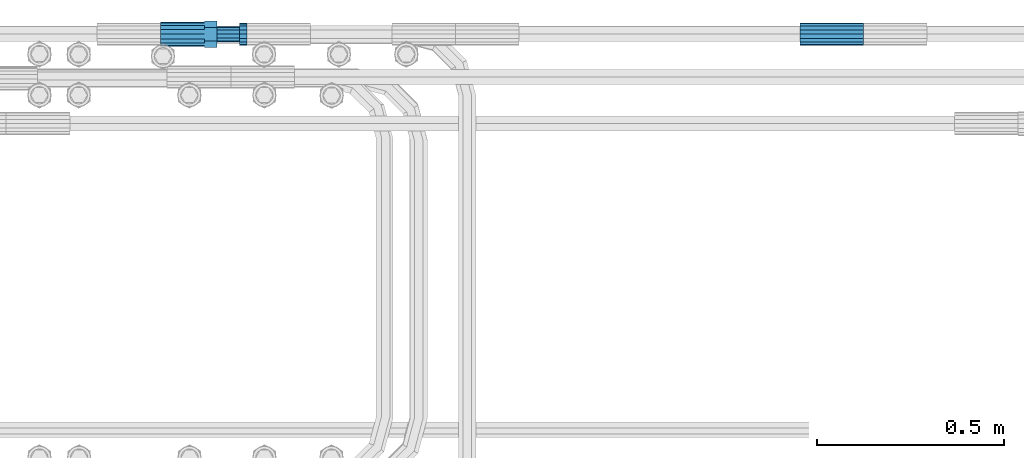
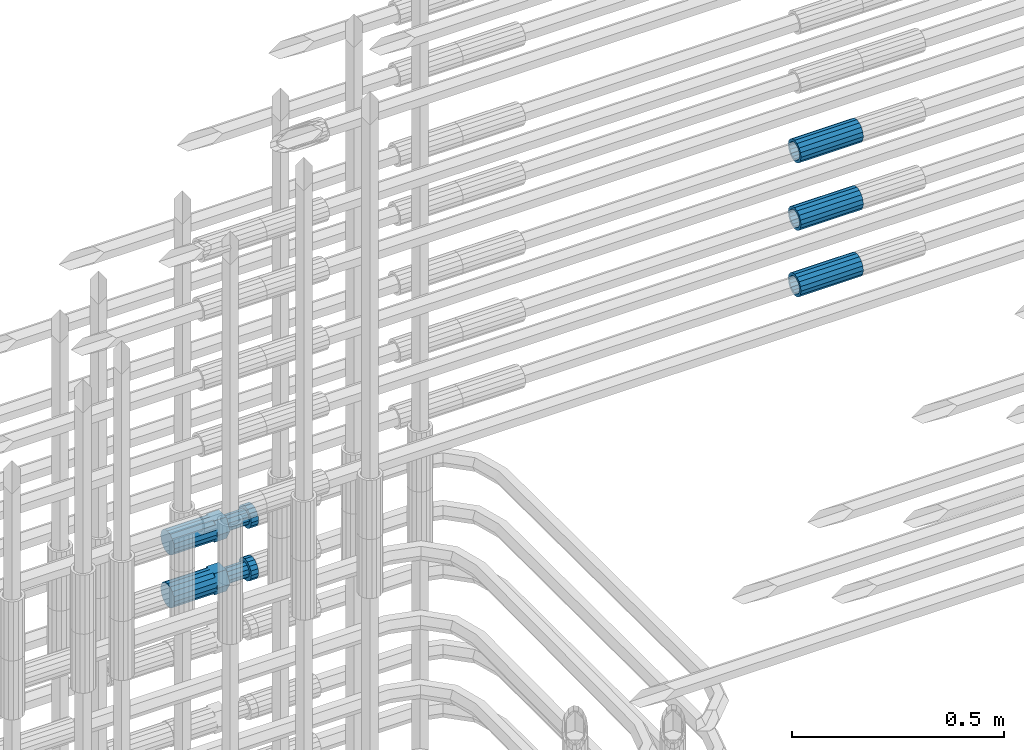
# One storey, part 82 of 119: 5 beams.
"""IFC2X3 building model written with IfcOpenShell, lengths in millimetres."""

from ifc_helpers import new_model, si_unit, frame, origin_with_axes, place, context, subcontext, project, spatial, faceted_brep, material, type_object, element, save


model = new_model("IFC2X3")

# Units and contexts
model_context = context("Model", 3, precision=1e-05, world=origin_with_axes())
body_context = subcontext(model_context, "Body", "Model", "MODEL_VIEW")
ifc_project = project(units=[si_unit("LENGTHUNIT", "METRE", prefix="MILLI"), si_unit("AREAUNIT", "SQUARE_METRE"), si_unit("VOLUMEUNIT", "CUBIC_METRE"), si_unit("MASSUNIT", "GRAM", prefix="KILO"), si_unit("TIMEUNIT", "SECOND"), si_unit("PLANEANGLEUNIT", "RADIAN"), si_unit("SOLIDANGLEUNIT", "STERADIAN"), si_unit("THERMODYNAMICTEMPERATUREUNIT", "DEGREE_CELSIUS"), si_unit("LUMINOUSINTENSITYUNIT", "LUMEN")], contexts=[model_context])

# Site, building, storey
site_placement = place(None, origin_with_axes())
site = spatial("IfcSite", under=ifc_project, at=site_placement, CompositionType="ELEMENT")
building_placement = place(site_placement, origin_with_axes())
building = spatial("IfcBuilding", under=site, at=building_placement, Name="Undefined", CompositionType="ELEMENT")
storey_placement = place(building_placement, origin_with_axes())
storey = spatial("IfcBuildingStorey", under=building, at=storey_placement, Name="Undefined", CompositionType="ELEMENT", Elevation=0.0)

# Beams
ifc_material = material(Name="STEEL/S275")
beam_type_1 = type_object("IfcBeamType", PredefinedType="NOTDEFINED")
beam_1_placement = place(storey_placement, frame((2037555.89023304, 6206399.98994599, 21049.6894003832), z_axis=(0.0, 0.0, 1.0), x_axis=(1.0, 0.0, 0.0)))
element("IfcBeam", 1, at=beam_1_placement, inside=storey, type_object=beam_type_1, material=ifc_material, Name="AG40N", context=body_context, shape_type="Brep", body=[
    faceted_brep([(1.62981450557709e-09, -23.4999999990687, 0.0), (7.45058059692383e-09, -21.7111690142192, 8.99306066057534), (170.000002125278, -21.711168999318, 8.99306066022245), (170.000002127141, -23.4999999844003, -3.66071617463604e-10), (4.65661287307739e-09, -16.6170093587134, 16.6170093578889), (170.000002122484, -16.6170093440451, 16.6170093575288), (1.86264514923096e-09, -8.99306066217832, 21.7111690140277), (170.000002118759, -8.99306064750999, 21.7111690136603), (2.3283064365387e-10, 9.31322574615479e-10, 23.5), (170.000002114102, 1.28056854009628e-08, 23.4999999996485), (-6.51925802230835e-09, 8.99306065868586, 21.7111690140241), (170.00000211224, 8.99306067335419, 21.7111690136639), (-7.45058059692383e-09, 16.6170093561523, 16.6170093578853), (170.000002109446, 16.6170093708206, 16.6170093575324), (-9.31322574615479e-09, 21.711169013055, 8.99306066057534), (170.000002108514, 21.7111690277234, 8.99306066022245), (-1.16415321826935e-09, 23.5000000009313, 0.0), (170.000002108514, 23.5000000144355, -3.66071617463604e-10), (-8.38190317153931e-09, 21.7111690151505, -8.99306066059444), (170.000002110377, 21.7111690300517, -8.9930606609546), (-5.58793544769287e-09, 16.6170093598776, -16.6170093579008), (170.000002113171, 16.6170093745459, -16.6170093582609), (-9.31322574615479e-10, 8.99306066334248, -21.7111690140396), (170.000002115965, 8.99306067801081, -21.7111690143961), (2.3283064365387e-10, 9.31322574615479e-10, -23.5), (170.00000211969, 1.7927959561348e-08, -23.5000000003843), (5.58793544769287e-09, -8.99306065752171, -21.7111690140396), (170.000002123415, -8.99306064285338, -21.7111690143961), (8.38190317153931e-09, -16.6170093549881, -16.6170093579008), (170.000002125278, -16.6170093403198, -16.6170093582646), (9.31322574615479e-09, -21.7111690121237, -8.99306066059444), (170.000002127141, -21.7111689972226, -8.9930606609546), (1.11758708953857e-08, -30.4999999990687, -9.54969436861575e-12), (1.30385160446167e-08, -28.1783257392235, -11.6718446871514), (170.000002129003, -28.1783257243223, -11.6718446875116), (170.000002129935, -30.4999999841675, -3.66071617463604e-10), (1.02445483207703e-08, -21.5667568228673, -21.5667568262129), (170.000002128072, -21.566756808199, -21.5667568265694), (7.45058059692383e-09, -11.6718446831219, -28.1783257416196), (170.000002125278, -11.6718446684536, -28.1783257419834), (3.72529029846191e-09, 3.95812094211578e-09, -30.5000000000277), (170.00000211969, 1.83936208486557e-08, -30.5000000003879), (-9.31322574615479e-10, 11.6718446905725, -28.1783257416232), (170.000002115965, 11.6718447052408, -28.1783257419797), (-6.51925802230835e-09, 21.5667568286881, -21.5667568262093), (170.000002110377, 21.5667568433564, -21.5667568265694), (-9.31322574615479e-09, 28.178325742716, -11.6718446871478), (170.000002108514, 28.1783257573843, -11.6718446875079), (-1.21071934700012e-08, 30.5, -5.91171556152403e-12), (170.000002106652, 30.5000000144355, -3.62433638656512e-10), (-1.21071934700012e-08, 28.1783257401548, 11.6718446871359), (170.00000210572, 28.1783257548232, 11.6718446867794), (-1.02445483207703e-08, 21.5667568240315, 21.5667568261974), (170.000002107583, 21.566756838467, 21.5667568258409), (-7.45058059692383e-09, 11.671844684286, 28.1783257416041), (170.000002110377, 11.6718446989544, 28.178325741244), (-2.79396772384644e-09, -2.56113708019257e-09, 30.5000000000159), (170.000002114102, 1.18743628263474e-08, 30.4999999996558), (1.86264514923096e-09, -11.6718446896411, 28.1783257416114), (170.000002118759, -11.67184467474, 28.178325741244), (7.45058059692383e-09, -21.5667568275239, 21.5667568261974), (170.000002123415, -21.5667568126228, 21.5667568258373), (1.02445483207703e-08, -28.1783257415518, 11.6718446871359), (170.000002127141, -28.1783257271163, 11.6718446867794)], [[[0, 1, 2, 3]], [[1, 4, 5, 2]], [[4, 6, 7, 5]], [[6, 8, 9, 7]], [[8, 10, 11, 9]], [[10, 12, 13, 11]], [[12, 14, 15, 13]], [[14, 16, 17, 15]], [[16, 18, 19, 17]], [[18, 20, 21, 19]], [[20, 22, 23, 21]], [[22, 24, 25, 23]], [[24, 26, 27, 25]], [[26, 28, 29, 27]], [[28, 30, 31, 29]], [[30, 0, 3, 31]], [[32, 33, 34, 35]], [[33, 36, 37, 34]], [[36, 38, 39, 37]], [[38, 40, 41, 39]], [[40, 42, 43, 41]], [[42, 44, 45, 43]], [[44, 46, 47, 45]], [[46, 48, 49, 47]], [[48, 50, 51, 49]], [[50, 52, 53, 51]], [[52, 54, 55, 53]], [[54, 56, 57, 55]], [[56, 58, 59, 57]], [[58, 60, 61, 59]], [[60, 62, 63, 61]], [[62, 32, 35, 63]], [[37, 39, 41, 43, 45, 47, 49, 51, 53, 55, 57, 59, 61, 63, 35, 34], [5, 7, 9, 11, 13, 15, 17, 19, 21, 23, 25, 27, 29, 31, 3, 2]], [[62, 60, 58, 56, 54, 52, 50, 48, 46, 44, 42, 40, 38, 36, 33, 32], [30, 28, 26, 24, 22, 20, 18, 16, 14, 12, 10, 8, 6, 4, 1, 0]]]),
])
beam_2_placement = place(storey_placement, frame((2037555.89023304, 6206399.98994599, 21240.9894003832), z_axis=(0.0, 0.0, 1.0), x_axis=(1.0, 0.0, 0.0)))
element("IfcBeam", 2, at=beam_2_placement, inside=storey, type_object=beam_type_1, material=ifc_material, Name="AG40N", context=body_context, shape_type="Brep", body=[
    faceted_brep([(1.62981450557709e-09, -23.4999999990687, 0.0), (7.45058059692383e-09, -21.7111690142192, 8.99306066057534), (170.000002125278, -21.711168999318, 8.99306066022245), (170.000002127141, -23.4999999844003, -3.66071617463604e-10), (4.65661287307739e-09, -16.6170093587134, 16.6170093578889), (170.000002122484, -16.6170093440451, 16.6170093575288), (1.86264514923096e-09, -8.99306066217832, 21.7111690140277), (170.000002118759, -8.99306064750999, 21.7111690136603), (2.3283064365387e-10, 9.31322574615479e-10, 23.5), (170.000002114102, 1.28056854009628e-08, 23.4999999996485), (-6.51925802230835e-09, 8.99306065868586, 21.7111690140241), (170.00000211224, 8.99306067335419, 21.7111690136639), (-7.45058059692383e-09, 16.6170093561523, 16.6170093578853), (170.000002109446, 16.6170093708206, 16.6170093575324), (-9.31322574615479e-09, 21.711169013055, 8.99306066057534), (170.000002108514, 21.7111690277234, 8.99306066022245), (-1.16415321826935e-09, 23.5000000009313, 0.0), (170.000002108514, 23.5000000144355, -3.66071617463604e-10), (-8.38190317153931e-09, 21.7111690151505, -8.99306066059444), (170.000002110377, 21.7111690300517, -8.9930606609546), (-5.58793544769287e-09, 16.6170093598776, -16.6170093579008), (170.000002113171, 16.6170093745459, -16.6170093582609), (-9.31322574615479e-10, 8.99306066334248, -21.7111690140396), (170.000002115965, 8.99306067801081, -21.7111690143961), (2.3283064365387e-10, 9.31322574615479e-10, -23.5), (170.00000211969, 1.7927959561348e-08, -23.5000000003843), (5.58793544769287e-09, -8.99306065752171, -21.7111690140396), (170.000002123415, -8.99306064285338, -21.7111690143961), (8.38190317153931e-09, -16.6170093549881, -16.6170093579008), (170.000002125278, -16.6170093403198, -16.6170093582646), (9.31322574615479e-09, -21.7111690121237, -8.99306066059444), (170.000002127141, -21.7111689972226, -8.9930606609546), (1.11758708953857e-08, -30.4999999990687, -9.54969436861575e-12), (1.30385160446167e-08, -28.1783257392235, -11.6718446871514), (170.000002129003, -28.1783257243223, -11.6718446875116), (170.000002129935, -30.4999999841675, -3.66071617463604e-10), (1.02445483207703e-08, -21.5667568228673, -21.5667568262129), (170.000002128072, -21.566756808199, -21.5667568265694), (7.45058059692383e-09, -11.6718446831219, -28.1783257416196), (170.000002125278, -11.6718446684536, -28.1783257419834), (3.72529029846191e-09, 3.95812094211578e-09, -30.5000000000277), (170.00000211969, 1.83936208486557e-08, -30.5000000003879), (-9.31322574615479e-10, 11.6718446905725, -28.1783257416232), (170.000002115965, 11.6718447052408, -28.1783257419797), (-6.51925802230835e-09, 21.5667568286881, -21.5667568262093), (170.000002110377, 21.5667568433564, -21.5667568265694), (-9.31322574615479e-09, 28.178325742716, -11.6718446871478), (170.000002108514, 28.1783257573843, -11.6718446875079), (-1.21071934700012e-08, 30.5, -5.91171556152403e-12), (170.000002106652, 30.5000000144355, -3.62433638656512e-10), (-1.21071934700012e-08, 28.1783257401548, 11.6718446871359), (170.00000210572, 28.1783257548232, 11.6718446867794), (-1.02445483207703e-08, 21.5667568240315, 21.5667568261974), (170.000002107583, 21.566756838467, 21.5667568258409), (-7.45058059692383e-09, 11.671844684286, 28.1783257416041), (170.000002110377, 11.6718446989544, 28.178325741244), (-2.79396772384644e-09, -2.56113708019257e-09, 30.5000000000159), (170.000002114102, 1.18743628263474e-08, 30.4999999996558), (1.86264514923096e-09, -11.6718446896411, 28.1783257416114), (170.000002118759, -11.67184467474, 28.178325741244), (7.45058059692383e-09, -21.5667568275239, 21.5667568261974), (170.000002123415, -21.5667568126228, 21.5667568258373), (1.02445483207703e-08, -28.1783257415518, 11.6718446871359), (170.000002127141, -28.1783257271163, 11.6718446867794)], [[[0, 1, 2, 3]], [[1, 4, 5, 2]], [[4, 6, 7, 5]], [[6, 8, 9, 7]], [[8, 10, 11, 9]], [[10, 12, 13, 11]], [[12, 14, 15, 13]], [[14, 16, 17, 15]], [[16, 18, 19, 17]], [[18, 20, 21, 19]], [[20, 22, 23, 21]], [[22, 24, 25, 23]], [[24, 26, 27, 25]], [[26, 28, 29, 27]], [[28, 30, 31, 29]], [[30, 0, 3, 31]], [[32, 33, 34, 35]], [[33, 36, 37, 34]], [[36, 38, 39, 37]], [[38, 40, 41, 39]], [[40, 42, 43, 41]], [[42, 44, 45, 43]], [[44, 46, 47, 45]], [[46, 48, 49, 47]], [[48, 50, 51, 49]], [[50, 52, 53, 51]], [[52, 54, 55, 53]], [[54, 56, 57, 55]], [[56, 58, 59, 57]], [[58, 60, 61, 59]], [[60, 62, 63, 61]], [[62, 32, 35, 63]], [[37, 39, 41, 43, 45, 47, 49, 51, 53, 55, 57, 59, 61, 63, 35, 34], [5, 7, 9, 11, 13, 15, 17, 19, 21, 23, 25, 27, 29, 31, 3, 2]], [[62, 60, 58, 56, 54, 52, 50, 48, 46, 44, 42, 40, 38, 36, 33, 32], [30, 28, 26, 24, 22, 20, 18, 16, 14, 12, 10, 8, 6, 4, 1, 0]]]),
])
beam_3_placement = place(storey_placement, frame((2037555.89023304, 6206399.98994599, 21434.9894003832), z_axis=(0.0, 0.0, 1.0), x_axis=(1.0, 0.0, 0.0)))
element("IfcBeam", 3, at=beam_3_placement, inside=storey, type_object=beam_type_1, material=ifc_material, Name="AG40N", context=body_context, shape_type="Brep", body=[
    faceted_brep([(1.62981450557709e-09, -23.4999999990687, 0.0), (7.45058059692383e-09, -21.7111690142192, 8.99306066057534), (170.000002125278, -21.711168999318, 8.99306066022245), (170.000002127141, -23.4999999844003, -3.66071617463604e-10), (4.65661287307739e-09, -16.6170093587134, 16.6170093578889), (170.000002122484, -16.6170093440451, 16.6170093575288), (1.86264514923096e-09, -8.99306066217832, 21.7111690140277), (170.000002118759, -8.99306064750999, 21.7111690136603), (2.3283064365387e-10, 9.31322574615479e-10, 23.5), (170.000002114102, 1.28056854009628e-08, 23.4999999996485), (-6.51925802230835e-09, 8.99306065868586, 21.7111690140241), (170.00000211224, 8.99306067335419, 21.7111690136639), (-7.45058059692383e-09, 16.6170093561523, 16.6170093578853), (170.000002109446, 16.6170093708206, 16.6170093575324), (-9.31322574615479e-09, 21.711169013055, 8.99306066057534), (170.000002108514, 21.7111690277234, 8.99306066022245), (-1.16415321826935e-09, 23.5000000009313, 0.0), (170.000002108514, 23.5000000144355, -3.66071617463604e-10), (-8.38190317153931e-09, 21.7111690151505, -8.99306066059444), (170.000002110377, 21.7111690300517, -8.9930606609546), (-5.58793544769287e-09, 16.6170093598776, -16.6170093579008), (170.000002113171, 16.6170093745459, -16.6170093582609), (-9.31322574615479e-10, 8.99306066334248, -21.7111690140396), (170.000002115965, 8.99306067801081, -21.7111690143961), (2.3283064365387e-10, 9.31322574615479e-10, -23.5), (170.00000211969, 1.7927959561348e-08, -23.5000000003843), (5.58793544769287e-09, -8.99306065752171, -21.7111690140396), (170.000002123415, -8.99306064285338, -21.7111690143961), (8.38190317153931e-09, -16.6170093549881, -16.6170093579008), (170.000002125278, -16.6170093403198, -16.6170093582646), (9.31322574615479e-09, -21.7111690121237, -8.99306066059444), (170.000002127141, -21.7111689972226, -8.9930606609546), (1.11758708953857e-08, -30.4999999990687, -9.54969436861575e-12), (1.30385160446167e-08, -28.1783257392235, -11.6718446871514), (170.000002129003, -28.1783257243223, -11.6718446875116), (170.000002129935, -30.4999999841675, -3.66071617463604e-10), (1.02445483207703e-08, -21.5667568228673, -21.5667568262129), (170.000002128072, -21.566756808199, -21.5667568265694), (7.45058059692383e-09, -11.6718446831219, -28.1783257416196), (170.000002125278, -11.6718446684536, -28.1783257419834), (3.72529029846191e-09, 3.95812094211578e-09, -30.5000000000277), (170.00000211969, 1.83936208486557e-08, -30.5000000003879), (-9.31322574615479e-10, 11.6718446905725, -28.1783257416232), (170.000002115965, 11.6718447052408, -28.1783257419797), (-6.51925802230835e-09, 21.5667568286881, -21.5667568262093), (170.000002110377, 21.5667568433564, -21.5667568265694), (-9.31322574615479e-09, 28.178325742716, -11.6718446871478), (170.000002108514, 28.1783257573843, -11.6718446875079), (-1.21071934700012e-08, 30.5, -5.91171556152403e-12), (170.000002106652, 30.5000000144355, -3.62433638656512e-10), (-1.21071934700012e-08, 28.1783257401548, 11.6718446871359), (170.00000210572, 28.1783257548232, 11.6718446867794), (-1.02445483207703e-08, 21.5667568240315, 21.5667568261974), (170.000002107583, 21.566756838467, 21.5667568258409), (-7.45058059692383e-09, 11.671844684286, 28.1783257416041), (170.000002110377, 11.6718446989544, 28.178325741244), (-2.79396772384644e-09, -2.56113708019257e-09, 30.5000000000159), (170.000002114102, 1.18743628263474e-08, 30.4999999996558), (1.86264514923096e-09, -11.6718446896411, 28.1783257416114), (170.000002118759, -11.67184467474, 28.178325741244), (7.45058059692383e-09, -21.5667568275239, 21.5667568261974), (170.000002123415, -21.5667568126228, 21.5667568258373), (1.02445483207703e-08, -28.1783257415518, 11.6718446871359), (170.000002127141, -28.1783257271163, 11.6718446867794)], [[[0, 1, 2, 3]], [[1, 4, 5, 2]], [[4, 6, 7, 5]], [[6, 8, 9, 7]], [[8, 10, 11, 9]], [[10, 12, 13, 11]], [[12, 14, 15, 13]], [[14, 16, 17, 15]], [[16, 18, 19, 17]], [[18, 20, 21, 19]], [[20, 22, 23, 21]], [[22, 24, 25, 23]], [[24, 26, 27, 25]], [[26, 28, 29, 27]], [[28, 30, 31, 29]], [[30, 0, 3, 31]], [[32, 33, 34, 35]], [[33, 36, 37, 34]], [[36, 38, 39, 37]], [[38, 40, 41, 39]], [[40, 42, 43, 41]], [[42, 44, 45, 43]], [[44, 46, 47, 45]], [[46, 48, 49, 47]], [[48, 50, 51, 49]], [[50, 52, 53, 51]], [[52, 54, 55, 53]], [[54, 56, 57, 55]], [[56, 58, 59, 57]], [[58, 60, 61, 59]], [[60, 62, 63, 61]], [[62, 32, 35, 63]], [[37, 39, 41, 43, 45, 47, 49, 51, 53, 55, 57, 59, 61, 63, 35, 34], [5, 7, 9, 11, 13, 15, 17, 19, 21, 23, 25, 27, 29, 31, 3, 2]], [[62, 60, 58, 56, 54, 52, 50, 48, 46, 44, 42, 40, 38, 36, 33, 32], [30, 28, 26, 24, 22, 20, 18, 16, 14, 12, 10, 8, 6, 4, 1, 0]]]),
])
beam_type_2 = type_object("IfcBeamType", Name="ROD65", PredefinedType="NOTDEFINED")
beam_4_placement = place(storey_placement, frame((2035848.65023304, 6206399.98994599, 20754.6894158506), z_axis=(0.0, 0.0, 1.0), x_axis=(1.0, 0.0, 0.0)))
element("IfcBeam", 4, at=beam_4_placement, inside=storey, type_object=beam_type_2, material=ifc_material, Name="AGB40", ObjectType="ROD65", context=body_context, shape_type="Brep", body=[
    faceted_brep([(116.999999999069, 17.8249999252148, 30.8738056446964), (116.999999998137, 22.0056957420893, 23.632628078838), (116.999999999069, 12.4372115600854, 30.0260848066173), (116.999999999069, 8.17543111252598, 30.8738056446964), (117.000000000931, -17.8250000746921, 30.8738056446964), (150.200000001118, -17.8250000723638, 30.8738056446964), (150.199999999255, 17.8249999275431, 30.8738056446964), (117.000000000931, -8.17543109622784, 30.8738056446964), (117.000000001863, -22.0056959956419, 23.6326278985034), (117.000000000931, -12.4372115437873, 30.0260848066173), (117.000000001863, -35.6500000746455, -2.18278728425503e-10), (150.200000002049, -35.6500000723172, -2.18278728425503e-10), (117.000000001863, -30.8443149488885, 8.32369080289209), (117.000000001863, -30.8443149488885, -8.32369080355784), (117.000000002794, -32.4999999918509, 0.0), (117.000000000931, -17.8250000746921, -30.873805645133), (150.200000001118, -17.8250000723638, -30.873805645133), (117.000000001863, -22.0056959961075, -23.6326278982269), (117.000000000931, -8.17543109389953, -30.873805645133), (117.000000000931, -12.4372115437873, -30.0260848066173), (116.999999999069, 17.8249999252148, -30.873805645133), (150.199999999255, 17.8249999275431, -30.873805645133), (116.999999999069, 8.17543111019768, -30.873805645133), (116.999999999069, 12.4372115600854, -30.0260848066173), (116.999999998137, 22.005695742555, -23.6326280785652), (116.999999998137, 35.6499999251682, -2.18278728425503e-10), (150.199999998324, 35.6499999277294, -2.18278728425503e-10), (116.999999998137, 30.8443150522653, -8.32369036550881), (116.999999997206, 32.5000000081491, 0.0), (116.999999998137, 30.8443150522653, 8.32369036483942), (1.86264514923096e-09, -22.9809703885112, 22.9809703885621), (1.86264514923096e-09, -30.0260848065373, 12.4372115518672), (117.000000001863, -30.0260847983882, 12.4372115518672), (117.000000001863, -22.9809703803621, 22.9809703885621), (-1.86264514923096e-09, 22.9809703885112, -22.9809703885621), (-1.86264514923096e-09, 30.0260848065373, -12.4372115518672), (116.999999998137, 30.0260848146863, -12.4372115518672), (116.999999998137, 22.9809703966603, -22.9809703885621), (1.86264514923096e-09, -30.0260848065373, -12.4372115518672), (1.86264514923096e-09, -22.9809703885112, -22.9809703885621), (117.000000001863, -22.9809703803621, -22.9809703885621), (117.000000001863, -30.0260847983882, -12.4372115518672), (9.31322574615479e-10, -12.4372115519363, 30.0260848066173), (0.0, 0.0, 32.5), (-9.31322574615479e-10, 12.4372115519363, 30.0260848066173), (-1.86264514923096e-09, 22.9809703885112, 22.9809703885621), (-1.86264514923096e-09, 30.0260848065373, 12.4372115518672), (-2.79396772384644e-09, 32.5, 0.0), (-9.31322574615479e-10, 12.4372115519363, -30.0260848066173), (0.0, 0.0, -32.5), (9.31322574615479e-10, -12.4372115519363, -30.0260848066173), (2.79396772384644e-09, -32.5, 0.0), (116.999999998137, 22.9809703966603, 22.9809703885621), (116.999999998137, 30.0260848146863, 12.4372115518672), (117.0, 8.14907252788544e-09, -32.5), (117.0, 8.14907252788544e-09, 32.5), (150.200000000186, -10.5000000959262, 18.1865334791873), (150.199999999255, -9.59262251853943e-08, 20.9999999997126), (150.199999998324, 10.4999999040738, 18.1865334791873), (150.199999997392, 18.1865333835594, 10.4999999997126), (150.199999997392, 20.9999999040738, -2.87400325760245e-10), (150.199999997392, 18.1865333835594, -10.5000000002874), (150.199999998324, 10.4999999040738, -18.1865334797621), (150.199999999255, -9.59262251853943e-08, -21.0000000002874), (150.200000000186, -10.5000000959262, -18.1865334797621), (150.200000000186, -18.1865335754119, -10.5000000002874), (150.200000001118, -21.0000000959262, -2.87400325760245e-10), (150.200000000186, -18.1865335754119, 10.4999999997126), (210.979999999516, 10.4999999082647, 18.1865334791873), (210.979999999516, -9.17352735996246e-08, 20.9999999997126), (210.979999997653, 18.1865333877504, 10.4999999997126), (210.979999997653, 20.9999999082647, -2.87400325760245e-10), (210.979999997653, 18.1865333877504, -10.5000000002874), (210.979999999516, 10.4999999082647, -18.1865334797621), (210.979999999516, -9.17352735996246e-08, -21.0000000002874), (210.979999999516, -10.5000000917353, -18.1865334797621), (210.980000000447, -18.1865335712209, -10.5000000002874), (210.980000001378, -21.0000000917353, -2.87400325760245e-10), (210.980000000447, -18.1865335712209, 10.4999999997126), (210.979999999516, -10.5000000917353, 18.1865334791873), (211.001368402503, -27.7269939335529, -11.4911163272045), (211.003082515672, -21.2238095656503, -21.2238154190527), (231.002518340945, -21.2131946226582, -21.2132004554769), (231.000804228708, -27.7163789905608, -11.4805013636287), (211.001368415542, -11.4911086384673, -27.7269970399575), (231.000804241747, -11.4804936954752, -27.7163820763781), (210.996487061493, -0.0106066407170147, -30.0106107396168), (230.995922887698, 8.30227509140968e-06, -29.999995776041), (210.98918159306, 11.4698940692469, -27.7269970332745), (230.988617419265, 11.4805090120062, -27.7163820696951), (210.980564201251, 21.2025913291145, -21.2238154067054), (230.980000027455, 21.2132062721066, -21.2132004431296), (210.971946807578, 27.7057702087332, -11.4911163110701), (230.971382633783, 27.7163851517253, -11.4805013474943), (210.964641331695, 29.9893806746695, -0.0106149565435771), (230.9640771579, 29.9999956176616, 7.03221303410828e-09), (210.959759964608, 27.7057637346443, 11.4698863966551), (230.959195790812, 27.7163786776364, 11.4805013602345), (210.958045851439, 21.2025793667417, 21.2025854885032), (230.957481677644, 21.2131943097338, 21.2132004520827), (210.959759951569, 11.4698784395587, 27.705767109408), (230.959195776843, 11.4804933823179, 27.7163820729838), (210.964641305618, -0.0106235581915826, 29.9893808090674), (230.964077131823, -8.61519947648048e-06, 29.9999957726432), (210.971946774051, -11.4911242681555, 27.7057671027251), (230.971382599324, -11.4805093251634, 27.7163820663009), (210.98056416586, -21.2238215280231, 21.2025854761559), (230.979999991134, -21.2132065852638, 21.2132004397354), (210.989181559533, -27.7270004076418, 11.4698863805206), (230.988617384806, -27.7163854646496, 11.4805013441), (210.996487035416, -30.0106108735781, -0.0106149740058754), (230.995922861621, -29.999995930586, -1.04300852399319e-08)], [[[0, 1, 2, 3]], [[4, 5, 6, 0, 3, 7]], [[8, 4, 7, 9]], [[10, 11, 5, 4, 8, 12]], [[13, 10, 12, 14]], [[15, 16, 11, 10, 13, 17]], [[18, 15, 17, 19]], [[20, 21, 16, 15, 18, 22]], [[20, 22, 23, 24]], [[25, 26, 21, 20, 24, 27]], [[25, 27, 28, 29]], [[30, 31, 32, 33]], [[34, 35, 36, 37]], [[38, 39, 40, 41]], [[31, 30, 42, 43, 44, 45, 46, 47, 35, 34, 48, 49, 50, 39, 38, 51]], [[46, 45, 52, 53]], [[28, 47, 46, 53, 29]], [[27, 36, 35, 47, 28]], [[24, 37, 36, 27]], [[23, 48, 34, 37, 24]], [[22, 54, 49, 48, 23]], [[18, 54, 22]], [[19, 50, 49, 54, 18]], [[17, 40, 39, 50, 19]], [[13, 41, 40, 17]], [[14, 51, 38, 41, 13]], [[12, 32, 31, 51, 14]], [[8, 33, 32, 12]], [[9, 42, 30, 33, 8]], [[7, 55, 43, 42, 9]], [[3, 55, 7]], [[2, 44, 43, 55, 3]], [[1, 52, 45, 44, 2]], [[29, 53, 52, 1]], [[0, 6, 26, 25, 29, 1]], [[5, 11, 16, 21, 26, 6], [56, 57, 58, 59, 60, 61, 62, 63, 64, 65, 66, 67]], [[68, 58, 57, 69]], [[70, 59, 58, 68]], [[71, 60, 59, 70]], [[72, 61, 60, 71]], [[73, 62, 61, 72]], [[74, 63, 62, 73]], [[75, 64, 63, 74]], [[76, 65, 64, 75]], [[77, 66, 65, 76]], [[78, 67, 66, 77]], [[79, 56, 67, 78]], [[69, 57, 56, 79]], [[80, 81, 82, 83]], [[81, 84, 85, 82]], [[84, 86, 87, 85]], [[86, 88, 89, 87]], [[88, 90, 91, 89]], [[90, 92, 93, 91]], [[92, 94, 95, 93]], [[94, 96, 97, 95]], [[96, 98, 99, 97]], [[98, 100, 101, 99]], [[100, 102, 103, 101]], [[102, 104, 105, 103]], [[104, 106, 107, 105]], [[106, 108, 109, 107]], [[108, 110, 111, 109]], [[82, 85, 87, 89, 91, 93, 95, 97, 99, 101, 103, 105, 107, 109, 111, 83]], [[110, 80, 83, 111]], [[108, 106, 104, 102, 100, 98, 96, 94, 92, 90, 88, 86, 84, 81, 80, 110], [78, 77, 76, 75, 74, 73, 72, 71, 70, 68, 69, 79]]]),
])
beam_5_placement = place(storey_placement, frame((2035848.66023304, 6206399.98994599, 20906.4894163789), z_axis=(0.0, 0.0, 1.0), x_axis=(1.0, 0.0, 0.0)))
element("IfcBeam", 5, at=beam_5_placement, inside=storey, type_object=beam_type_2, material=ifc_material, Name="AGB40", ObjectType="ROD65", context=body_context, shape_type="Brep", body=[
    faceted_brep([(116.999999999069, 17.8249999252148, 30.8738056446964), (116.999999998137, 22.0056957420893, 23.632628078838), (116.999999999069, 12.4372115600854, 30.0260848066173), (116.999999999069, 8.17543111252598, 30.8738056446964), (117.000000000931, -17.8250000746921, 30.8738056446964), (150.200000001118, -17.8250000723638, 30.8738056446964), (150.199999999255, 17.8249999275431, 30.8738056446964), (117.000000000931, -8.17543109622784, 30.8738056446964), (117.000000001863, -22.0056959956419, 23.6326278985034), (117.000000000931, -12.4372115437873, 30.0260848066173), (117.000000001863, -35.6500000746455, -2.18278728425503e-10), (150.200000002049, -35.6500000723172, -2.18278728425503e-10), (117.000000001863, -30.8443149488885, 8.32369080289209), (117.000000001863, -30.8443149488885, -8.32369080355784), (117.000000002794, -32.4999999918509, 0.0), (117.000000000931, -17.8250000746921, -30.873805645133), (150.200000001118, -17.8250000723638, -30.873805645133), (117.000000001863, -22.0056959961075, -23.6326278982269), (117.000000000931, -8.17543109389953, -30.873805645133), (117.000000000931, -12.4372115437873, -30.0260848066173), (116.999999999069, 17.8249999252148, -30.873805645133), (150.199999999255, 17.8249999275431, -30.873805645133), (116.999999999069, 8.17543111019768, -30.873805645133), (116.999999999069, 12.4372115600854, -30.0260848066173), (116.999999998137, 22.005695742555, -23.6326280785652), (116.999999998137, 35.6499999251682, -2.18278728425503e-10), (150.199999998324, 35.6499999277294, -2.18278728425503e-10), (116.999999998137, 30.8443150522653, -8.32369036550881), (116.999999997206, 32.5000000081491, 0.0), (116.999999998137, 30.8443150522653, 8.32369036483942), (1.86264514923096e-09, -22.9809703885112, 22.9809703885621), (1.86264514923096e-09, -30.0260848065373, 12.4372115518672), (117.000000001863, -30.0260847983882, 12.4372115518672), (117.000000001863, -22.9809703803621, 22.9809703885621), (-1.86264514923096e-09, 22.9809703885112, -22.9809703885621), (-1.86264514923096e-09, 30.0260848065373, -12.4372115518672), (116.999999998137, 30.0260848146863, -12.4372115518672), (116.999999998137, 22.9809703966603, -22.9809703885621), (1.86264514923096e-09, -30.0260848065373, -12.4372115518672), (1.86264514923096e-09, -22.9809703885112, -22.9809703885621), (117.000000001863, -22.9809703803621, -22.9809703885621), (117.000000001863, -30.0260847983882, -12.4372115518672), (9.31322574615479e-10, -12.4372115519363, 30.0260848066173), (0.0, 0.0, 32.5), (-9.31322574615479e-10, 12.4372115519363, 30.0260848066173), (-1.86264514923096e-09, 22.9809703885112, 22.9809703885621), (-1.86264514923096e-09, 30.0260848065373, 12.4372115518672), (-2.79396772384644e-09, 32.5, 0.0), (-9.31322574615479e-10, 12.4372115519363, -30.0260848066173), (0.0, 0.0, -32.5), (9.31322574615479e-10, -12.4372115519363, -30.0260848066173), (2.79396772384644e-09, -32.5, 0.0), (116.999999998137, 22.9809703966603, 22.9809703885621), (116.999999998137, 30.0260848146863, 12.4372115518672), (117.0, 8.14907252788544e-09, -32.5), (117.0, 8.14907252788544e-09, 32.5), (150.200000000186, -10.5000000959262, 18.1865334791873), (150.199999999255, -9.59262251853943e-08, 20.9999999997126), (150.199999998324, 10.4999999040738, 18.1865334791873), (150.199999997392, 18.1865333835594, 10.4999999997126), (150.199999997392, 20.9999999040738, -2.87400325760245e-10), (150.199999997392, 18.1865333835594, -10.5000000002874), (150.199999998324, 10.4999999040738, -18.1865334797621), (150.199999999255, -9.59262251853943e-08, -21.0000000002874), (150.200000000186, -10.5000000959262, -18.1865334797621), (150.200000000186, -18.1865335754119, -10.5000000002874), (150.200000001118, -21.0000000959262, -2.87400325760245e-10), (150.200000000186, -18.1865335754119, 10.4999999997126), (210.979999999516, 10.4999999082647, 18.1865334791873), (210.979999999516, -9.17352735996246e-08, 20.9999999997126), (210.979999997653, 18.1865333877504, 10.4999999997126), (210.979999997653, 20.9999999082647, -2.87400325760245e-10), (210.979999997653, 18.1865333877504, -10.5000000002874), (210.979999999516, 10.4999999082647, -18.1865334797621), (210.979999999516, -9.17352735996246e-08, -21.0000000002874), (210.979999999516, -10.5000000917353, -18.1865334797621), (210.980000000447, -18.1865335712209, -10.5000000002874), (210.980000001378, -21.0000000917353, -2.87400325760245e-10), (210.980000000447, -18.1865335712209, 10.4999999997126), (210.979999999516, -10.5000000917353, 18.1865334791873), (211.001368402503, -27.7269939335529, -11.4911163272045), (211.003082515672, -21.2238095656503, -21.2238154190527), (231.002518340945, -21.2131946226582, -21.2132004554769), (231.000804228708, -27.7163789905608, -11.4805013636287), (211.001368415542, -11.4911086384673, -27.7269970399575), (231.000804241747, -11.4804936954752, -27.7163820763781), (210.996487061493, -0.0106066407170147, -30.0106107396168), (230.995922887698, 8.30227509140968e-06, -29.999995776041), (210.98918159306, 11.4698940692469, -27.7269970332745), (230.988617419265, 11.4805090120062, -27.7163820696951), (210.980564201251, 21.2025913291145, -21.2238154067054), (230.980000027455, 21.2132062721066, -21.2132004431296), (210.971946807578, 27.7057702087332, -11.4911163110701), (230.971382633783, 27.7163851517253, -11.4805013474943), (210.964641331695, 29.9893806746695, -0.0106149565435771), (230.9640771579, 29.9999956176616, 7.03221303410828e-09), (210.959759964608, 27.7057637346443, 11.4698863966551), (230.959195790812, 27.7163786776364, 11.4805013602345), (210.958045851439, 21.2025793667417, 21.2025854885032), (230.957481677644, 21.2131943097338, 21.2132004520827), (210.959759951569, 11.4698784395587, 27.705767109408), (230.959195776843, 11.4804933823179, 27.7163820729838), (210.964641305618, -0.0106235581915826, 29.9893808090674), (230.964077131823, -8.61519947648048e-06, 29.9999957726432), (210.971946774051, -11.4911242681555, 27.7057671027251), (230.971382599324, -11.4805093251634, 27.7163820663009), (210.98056416586, -21.2238215280231, 21.2025854761559), (230.979999991134, -21.2132065852638, 21.2132004397354), (210.989181559533, -27.7270004076418, 11.4698863805206), (230.988617384806, -27.7163854646496, 11.4805013441), (210.996487035416, -30.0106108735781, -0.0106149740058754), (230.995922861621, -29.999995930586, -1.04300852399319e-08)], [[[0, 1, 2, 3]], [[4, 5, 6, 0, 3, 7]], [[8, 4, 7, 9]], [[10, 11, 5, 4, 8, 12]], [[13, 10, 12, 14]], [[15, 16, 11, 10, 13, 17]], [[18, 15, 17, 19]], [[20, 21, 16, 15, 18, 22]], [[20, 22, 23, 24]], [[25, 26, 21, 20, 24, 27]], [[25, 27, 28, 29]], [[30, 31, 32, 33]], [[34, 35, 36, 37]], [[38, 39, 40, 41]], [[31, 30, 42, 43, 44, 45, 46, 47, 35, 34, 48, 49, 50, 39, 38, 51]], [[46, 45, 52, 53]], [[28, 47, 46, 53, 29]], [[27, 36, 35, 47, 28]], [[24, 37, 36, 27]], [[23, 48, 34, 37, 24]], [[22, 54, 49, 48, 23]], [[18, 54, 22]], [[19, 50, 49, 54, 18]], [[17, 40, 39, 50, 19]], [[13, 41, 40, 17]], [[14, 51, 38, 41, 13]], [[12, 32, 31, 51, 14]], [[8, 33, 32, 12]], [[9, 42, 30, 33, 8]], [[7, 55, 43, 42, 9]], [[3, 55, 7]], [[2, 44, 43, 55, 3]], [[1, 52, 45, 44, 2]], [[29, 53, 52, 1]], [[0, 6, 26, 25, 29, 1]], [[5, 11, 16, 21, 26, 6], [56, 57, 58, 59, 60, 61, 62, 63, 64, 65, 66, 67]], [[68, 58, 57, 69]], [[70, 59, 58, 68]], [[71, 60, 59, 70]], [[72, 61, 60, 71]], [[73, 62, 61, 72]], [[74, 63, 62, 73]], [[75, 64, 63, 74]], [[76, 65, 64, 75]], [[77, 66, 65, 76]], [[78, 67, 66, 77]], [[79, 56, 67, 78]], [[69, 57, 56, 79]], [[80, 81, 82, 83]], [[81, 84, 85, 82]], [[84, 86, 87, 85]], [[86, 88, 89, 87]], [[88, 90, 91, 89]], [[90, 92, 93, 91]], [[92, 94, 95, 93]], [[94, 96, 97, 95]], [[96, 98, 99, 97]], [[98, 100, 101, 99]], [[100, 102, 103, 101]], [[102, 104, 105, 103]], [[104, 106, 107, 105]], [[106, 108, 109, 107]], [[108, 110, 111, 109]], [[82, 85, 87, 89, 91, 93, 95, 97, 99, 101, 103, 105, 107, 109, 111, 83]], [[110, 80, 83, 111]], [[108, 106, 104, 102, 100, 98, 96, 94, 92, 90, 88, 86, 84, 81, 80, 110], [78, 77, 76, 75, 74, 73, 72, 71, 70, 68, 69, 79]]]),
])

save(model, "model.ifc")
